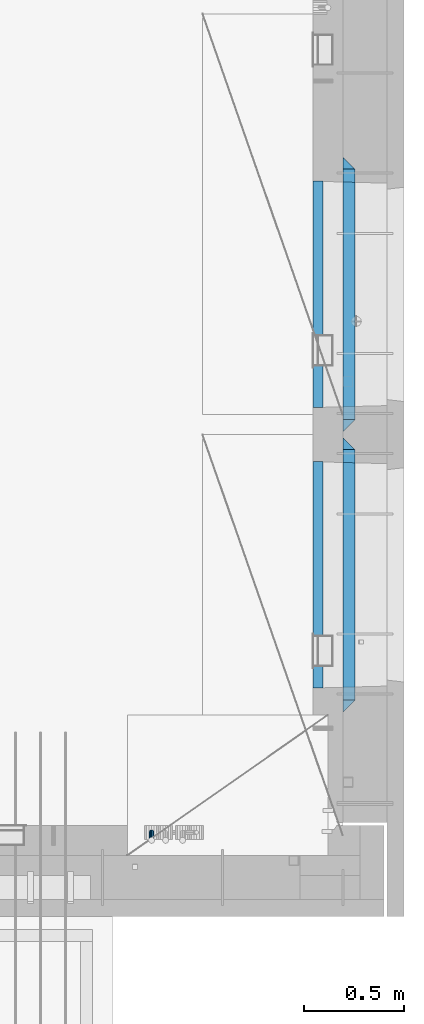
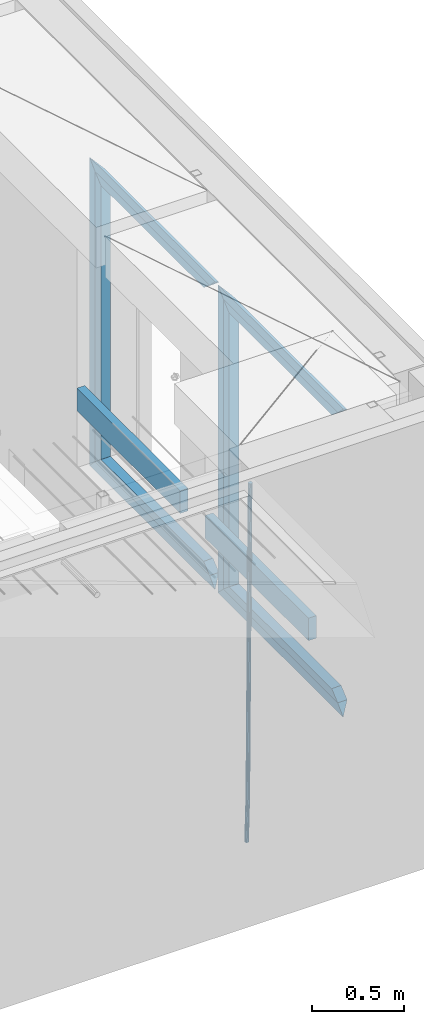
# One storey, part 131 of 349: 15 beams, 2 elements without a shape of their own.
"""IFC2X3 building model written with IfcOpenShell, lengths in millimetres."""

from ifc_helpers import new_model, si_unit, frame, origin_with_axes, place, context, subcontext, project, spatial, faceted_brep, material, type_object, element, aggregate, save


model = new_model("IFC2X3")

# Units and contexts
model_context = context("Model", 3, precision=1e-05, world=origin_with_axes())
body_context = subcontext(model_context, "Body", "Model", "MODEL_VIEW")
ifc_project = project(units=[si_unit("LENGTHUNIT", "METRE", prefix="MILLI"), si_unit("AREAUNIT", "SQUARE_METRE"), si_unit("VOLUMEUNIT", "CUBIC_METRE"), si_unit("MASSUNIT", "GRAM", prefix="KILO"), si_unit("TIMEUNIT", "SECOND"), si_unit("PLANEANGLEUNIT", "RADIAN"), si_unit("SOLIDANGLEUNIT", "STERADIAN"), si_unit("THERMODYNAMICTEMPERATUREUNIT", "DEGREE_CELSIUS"), si_unit("LUMINOUSINTENSITYUNIT", "LUMEN")], contexts=[model_context])

# Site, building, storey
site_placement = place(None, origin_with_axes())
site = spatial("IfcSite", under=ifc_project, at=site_placement, CompositionType="ELEMENT")
building_placement = place(site_placement, origin_with_axes())
building = spatial("IfcBuilding", under=site, at=building_placement, CompositionType="ELEMENT")
storey_placement = place(building_placement, origin_with_axes())
storey = spatial("IfcBuildingStorey", under=building, at=storey_placement, Name="4", CompositionType="ELEMENT", Elevation=0.0)

# Assembly, beam
assembly_1_placement = place(storey_placement, origin_with_axes())
assembly_1 = element("IfcElementAssembly", 1, at=assembly_1_placement, inside=storey, AssemblyPlace="NOTDEFINED", PredefinedType="REINFORCEMENT_UNIT")
ifc_material_1 = material()
beam_type_1 = type_object("IfcBeamType", Name="D25", PredefinedType="NOTDEFINED")
beam_1_placement = place(assembly_1_placement, frame((34104.9999999961, 7965.00000227913, 90990.0), z_axis=(0.00020576299992186, -0.999642804629538, -0.0267249099901004), x_axis=(-4.30000201928125e-08, -0.0267249099948059, 0.999642825806181)))
beam_1 = element("IfcBeam", 2, at=beam_1_placement, type_object=beam_type_1, material=ifc_material_1, Name="JM25", ObjectType="D25", context=body_context, shape_type="Brep", body=[
    faceted_brep([(-7.41420080885291e-08, -12.5, -3.63797880709171e-12), (-6.42030499875546e-08, -10.8253175473074, -6.25000000000364), (60.4103898235917, -10.8253175318459, -6.2499999938409), (60.4103898269532, -12.4999999845422, 6.16273609921336e-09), (-3.70782800018787e-08, -6.25000000000364, -10.8253175473074), (60.4103898202884, -6.24999998454587, -10.8253175411446), (-1.45519152283669e-11, -3.63797880709171e-12, -12.5), (60.4103898179019, 1.54577719513327e-08, -12.4999999938373), (3.70637280866504e-08, 6.25, -10.8253175473074), (60.410389817087, 6.25000001545777, -10.825317541141), (6.42030499875546e-08, 10.8253175473001, -6.25000000000364), (60.410389818062, 10.8253175627578, -6.24999999383726), (7.41420080885291e-08, 12.4999999999927, 0.0), (60.4103898205503, 12.5000000154541, 6.16273609921336e-09), (6.42176019027829e-08, 10.8253175473001, 6.24999999999636), (60.4103898238973, 10.8253175627651, 6.2500000061591), (3.70928319171071e-08, 6.24999999999636, 10.8253175473037), (60.4103898272151, 6.25000001546141, 10.8253175534664), (1.45519152283669e-11, -3.63797880709171e-12, 12.4999999999964), (60.4103898296162, 1.54541339725256e-08, 12.5000000061591), (-3.7049176171422e-08, -6.25000000000364, 10.8253175473001), (60.4103898304165, -6.24999998454587, 10.8253175534701), (-6.41884980723262e-08, -10.8253175473074, 6.25), (60.4103898294561, -10.8253175318459, 6.25000000616637), (61.0324985728803, -10.8253175316895, -6.24999999377542), (60.991802792938, -12.4999999843931, 6.22458173893392e-09), (61.0622854283865, -6.24999998437852, -10.8253175410755), (61.0731819955545, 1.5628756955266e-08, -12.4999999937718), (61.0622685480339, 6.25000001562512, -10.8253175410791), (61.032469335245, 10.8253175629216, -6.24999999377178), (60.9917690322181, 12.5000000156033, 6.22458173893392e-09), (60.9510732522613, 10.8253175629034, 6.25000000621731), (60.9212863967696, 6.25000001558874, 10.8253175535247), (60.9103898296162, 1.55814632307738e-08, 12.5000000062137), (60.9213032771368, -6.24999998441126, 10.8253175535174), (60.9511024898966, -10.8253175317113, 6.25000000621731), (61.6545545670233, -10.8253158516927, -6.24189838219536), (61.573166454793, -12.499998414296, 0.00757164385504439), (61.7141257553885, -6.24999822394238, -10.8168280205282), (61.7359179680789, 1.80548886419274e-06, -12.491368569139), (61.7140919992817, 6.25000177601396, -10.8168282403167), (61.6544960997562, 10.8253192428383, -6.2418987628771), (61.5730989426083, 12.5000015856094, 0.0075712042817031), (61.4917108303925, 10.8253190230062, 6.25704123032847), (61.4321396420273, 6.25000139525582, 10.8319708686649), (61.4103474293224, 1.36582457344048e-06, 12.5065114172721), (61.4321733981196, -6.24999860470052, 10.8319710884571), (61.4917692976451, -10.8253160715249, 6.25704161101385), (176.524302641745, -10.8250056210964, -4.74584321979273), (176.442914529529, -12.4996881836996, 1.50362680625403), (176.583873830095, -6.24968799334965, -9.3207728581292), (176.605666042786, 0.000312036081595579, -10.9953134067364), (176.583840074018, 6.25031200660669, -9.32077307791769), (176.524244174492, 10.8256294734347, -4.74584360047811), (176.44284701733, 12.5003118162058, 1.50362636668069), (176.361458905099, 10.8256292535989, 7.75309639272746), (176.301887716749, 6.25031162585219, 12.3280260310676), (176.280095504058, 0.000311596420942806, 14.0025665796711), (176.301921472827, -6.24968837410415, 12.3280262508561), (176.361517372367, -10.8250058409321, 7.75309677341284), (177.085397012124, -10.8250041057399, -4.73853556792164), (176.983633547483, -12.4996867233749, 1.51066909103247), (177.159881729676, -6.24968643771717, -9.31327097355097), (177.187129580227, 0.000313606451527448, -10.987740468332), (177.159839524218, 6.25031356221734, -9.31327130338468), (177.085323910098, 10.8256309887511, -4.73853613920801), (176.983549136537, 12.5003132764905, 1.51066843136869), (176.881785671867, 10.8256306588555, 7.7598730903228), (176.80730095433, 6.25031299082912, 12.3346084959521), (176.780053103794, 0.000312946667690994, 14.0090779907332), (176.807343159802, -6.2496870091054, 12.3346088257895), (176.881858773908, -10.8250044356355, 7.7598736616128), (177.646431799818, -10.8250018318176, -4.72756919822132), (177.524295146417, -12.4996845320202, 1.52123723245313), (177.735828462886, -6.24968410334986, -9.30201312475765), (177.768531371941, 0.00031596292683389, -10.9763759912421), (177.735777808921, 6.25031589654827, -9.30201361973741), (177.646344064575, 10.8256332626152, -4.72757005553649), (177.524193838486, 12.5003154677688, 1.52123624250817), (177.402057185071, 10.8256327675663, 7.77004267317898), (177.312660521988, 6.2503150390985, 12.3444865997226), (177.279957612933, 0.00031497282179771, 14.0188494661961), (177.312711175953, -6.24968496079964, 12.3444870946951), (177.402144920314, -10.8250023268702, 7.77004353049415), (299.377443161706, -10.8245084454466, -2.34813158632096), (299.255306508276, -12.4991911456491, 3.90067484435349), (299.466839824803, -6.24919071697514, -6.92257551286093), (299.499542733873, 0.0008093492979242, -8.59693837933446), (299.466789170867, 6.250809282923, -6.92257600783341), (299.377355426492, 10.8261266489935, -2.34813244364341), (299.255205200388, 12.5008088541435, 3.90067385440125), (299.133068546944, 10.826126153941, 10.1494802850757), (299.043671883861, 6.25080842546959, 14.7239242116229), (299.010968974762, 0.000808359200163977, 16.3982870780892), (299.043722537797, -6.24919157442127, 14.7239247065918), (299.133156282158, -10.8245089404954, 10.1494811423981), (299.98561436501, -10.8245059804758, -2.33624385599614), (299.97179243555, -12.4991882411778, 3.91467976726199), (299.995742293278, -6.24918857328521, -6.91223722345239), (299.999447243041, 0.000811375455668895, -8.58716690387519), (299.995736475976, 6.25081142679483, -6.91223684201032), (299.985604289133, 10.8261291142808, -2.33624319533556), (299.971750386685, 12.5008117588586, 3.91467993563856), (299.957928457196, 10.8261294971744, 10.1656035610831), (299.947800528913, 6.25081208998381, 14.7415969285394), (299.944095579151, 0.00081214124293183, 16.4165266089549), (299.947806346216, -6.24918791008895, 14.7415965471009), (299.957938533058, -10.8245055975785, 10.1656029004225), (300.593832239858, -10.8245078794353, -2.34543881707941), (300.688302931099, -12.4991904788549, 3.90384712594823), (300.524685350189, -6.24919022474205, -6.92023371784308), (300.499390115292, 0.000809814544481924, -8.59472497713432), (300.524724372954, 6.25080977519247, -6.92023401429469), (300.593899829313, 10.8261272150703, -2.34543933054374), (300.688380976673, 12.5008095210287, 3.90384653304136), (300.782851667915, 10.8261269216127, 10.1531324760799), (300.851998557599, 6.25080926691589, 14.7279273768363), (300.877293792495, 0.000809227632998955, 16.4024186361276), (300.851959534804, -6.24919073302226, 14.7279276732806), (300.782784078474, -10.8245081728965, 10.153132989537), (2293.32930409742, -10.8307295605009, -32.4713622331001), (2293.42377478865, -12.5054121599169, -26.2220762900724), (2293.26015720774, -6.2554119058077, -37.0461571338565), (2293.23486197284, -0.00541186651753378, -38.7206483931477), (2293.26019623051, 6.24458809413409, -37.0461574303008), (2293.32937168686, 10.8199055340046, -32.4713627465644), (2293.42385283421, 12.4945878399631, -26.2220768829684), (2293.51832352545, 10.8199052405434, -19.972790939948), (2293.58747041514, 6.24458758585388, -15.3979960391844), (2293.61276565003, -0.00541245343265473, -13.7235047798931), (2293.58743139236, -6.25541241408428, -15.3979957427327), (2293.51825593603, -10.8307298539585, -19.9727904264691), (2294.0420846676, -10.8307317859326, -32.4821379598216), (2294.03681932652, -12.5054140739521, -26.2313442200393), (2294.06778164886, -6.2554144273563, -37.0583666982457), (2294.10702478497, -0.00541458957013674, -38.7338336404937), (2294.14929890928, 6.24458531819619, -37.0595987724118), (2294.18327670435, 10.8199028679592, -32.4842719748667), (2294.1998538474, 12.4945854171456, -26.2338083683717), (2294.19458850632, 10.819903129126, -19.9830146285858), (2294.16889152506, 6.24458577054975, -15.4067858901581), (2294.12964838895, -0.0054140672327776, -13.7313189479173), (2294.08737426462, -6.2554139749991, -15.4055538159919), (2294.05339646956, -10.8307315247621, -19.9808806135297), (2294.75482297382, -10.84002603931, -32.4726521173216), (2294.64982751427, -12.513407826169, -26.2231856868602), (2294.87535820232, -6.26594539088183, -37.0476186524102), (2294.97913588268, -0.0167870967634371, -38.7222267036377), (2295.0383488692, 6.23299192477134, -37.0477663960555), (2295.03713108998, 10.8087684320271, -32.4729080168181), (2294.97580884799, 12.4844668051373, -26.2234811741473), (2294.87081338844, 10.8110850182784, -19.9740147436787), (2294.7502781599, 6.23700436985018, -15.3990482086047), (2294.64650047956, -0.0121539242718427, -13.7244401573698), (2294.58728749304, -6.26193294580662, -15.3989004649666), (2294.58850527227, -10.8377094530588, -19.9737588441894), (2316.44667268227, -11.1228921988077, -32.1839550346631), (2316.34167722271, -12.7962739856739, -25.9344886042054), (2316.56720791078, -6.54881155039038, -36.7589215697517), (2316.67098559113, -0.299653256264719, -38.4335296209792), (2316.73019857766, 5.95012576527006, -36.759069313397), (2316.72898079845, 10.5259022725259, -32.1842109341669), (2316.66765855643, 12.2016006456361, -25.9347840914961), (2316.56266309689, 10.5282188587698, -19.6853176610275), (2316.44212786836, 5.95413821035254, -15.1103511259389), (2316.33835018802, -0.295020083769487, -13.4357430747186), (2316.27913720149, -6.54479910530426, -15.1102033823008), (2316.28035498071, -11.1205756125637, -19.685061761531), (2317.13234804722, -11.1318335458927, -32.1748293731798), (2317.04181141085, -12.8054038787741, -25.9251705100723), (2317.2154741603, -6.5572650749491, -36.7502937866229), (2317.26891617525, -0.307450393454928, -38.4255717558117), (2317.27835434731, 5.94297770185585, -36.7517739018112), (2317.24125972588, 10.5192220504723, -32.1773930078925), (2317.16757178486, 12.1950816748285, -25.9281307404563), (2317.0770351485, 10.5215113419545, -19.6784718773561), (2316.99390903539, 5.94694287101083, -15.1030074639057), (2316.94046702047, -0.302871810494253, -13.4277294947169), (2316.9310288484, -6.55329990579412, -15.1015273487101), (2316.96812346982, -11.1295442544142, -19.6759082426288), (2317.81808136747, -11.1298054502913, -32.1659056455355), (2317.74200467508, -12.803315894289, -25.9160547315114), (2317.86379538118, -6.55536082026447, -36.7418676070083), (2317.8668976831, -0.305700748642266, -38.417815303761), (2317.82655701396, 5.94458339541234, -36.7446799039099), (2317.75358262347, 10.5207330230332, -32.1707766866384), (2317.66752794063, 12.1965725370646, -25.9216793252963), (2317.59145124823, 10.5230620930706, -19.6718284112721), (2317.54573723453, 5.94861746304377, -15.0958664497994), (2317.54263493262, -0.301042608574789, -13.4199187530394), (2317.58297560175, -6.55132675263303, -15.0930541529051), (2317.65594999224, -11.1274763802539, -19.6669573701693), (2417.81884292323, -10.831603083323, -30.8687911350135), (2417.74276623082, -12.505113527317, -24.618940220982), (2417.86455693691, -6.25715845329614, -35.4447530964935), (2417.86765923884, -0.00749838167394046, -37.1207007932499), (2417.82731856969, 6.24278576237703, -35.4475653933878), (2417.75434417921, 10.8189353900088, -30.8736621761236), (2417.66828949639, 12.494774904033, -24.6245648147851), (2417.59221280397, 10.8212644600353, -18.3747139007501), (2417.54649879028, 6.2468198300121, -13.79875193927), (2417.54339648837, -0.00284024161010166, -12.1228042425173), (2417.5837371575, -6.25312438566107, -13.795939642383), (2417.65671154798, -10.8292740132893, -18.3698428596399)], [[[0, 1, 2, 3]], [[1, 4, 5, 2]], [[4, 6, 7, 5]], [[6, 8, 9, 7]], [[8, 10, 11, 9]], [[10, 12, 13, 11]], [[12, 14, 15, 13]], [[14, 16, 17, 15]], [[16, 18, 19, 17]], [[18, 20, 21, 19]], [[20, 22, 23, 21]], [[22, 0, 3, 23]], [[22, 20, 18, 16, 14, 12, 10, 8, 6, 4, 1, 0]], [[3, 2, 24, 25]], [[2, 5, 26, 24]], [[5, 7, 27, 26]], [[7, 9, 28, 27]], [[9, 11, 29, 28]], [[11, 13, 30, 29]], [[13, 15, 31, 30]], [[15, 17, 32, 31]], [[17, 19, 33, 32]], [[19, 21, 34, 33]], [[21, 23, 35, 34]], [[23, 3, 25, 35]], [[25, 24, 36, 37]], [[24, 26, 38, 36]], [[26, 27, 39, 38]], [[27, 28, 40, 39]], [[28, 29, 41, 40]], [[29, 30, 42, 41]], [[30, 31, 43, 42]], [[31, 32, 44, 43]], [[32, 33, 45, 44]], [[33, 34, 46, 45]], [[34, 35, 47, 46]], [[35, 25, 37, 47]], [[37, 36, 48, 49]], [[36, 38, 50, 48]], [[38, 39, 51, 50]], [[39, 40, 52, 51]], [[40, 41, 53, 52]], [[41, 42, 54, 53]], [[42, 43, 55, 54]], [[43, 44, 56, 55]], [[44, 45, 57, 56]], [[45, 46, 58, 57]], [[46, 47, 59, 58]], [[47, 37, 49, 59]], [[49, 48, 60, 61]], [[48, 50, 62, 60]], [[50, 51, 63, 62]], [[51, 52, 64, 63]], [[52, 53, 65, 64]], [[53, 54, 66, 65]], [[54, 55, 67, 66]], [[55, 56, 68, 67]], [[56, 57, 69, 68]], [[57, 58, 70, 69]], [[58, 59, 71, 70]], [[59, 49, 61, 71]], [[61, 60, 72, 73]], [[60, 62, 74, 72]], [[62, 63, 75, 74]], [[63, 64, 76, 75]], [[64, 65, 77, 76]], [[65, 66, 78, 77]], [[66, 67, 79, 78]], [[67, 68, 80, 79]], [[68, 69, 81, 80]], [[69, 70, 82, 81]], [[70, 71, 83, 82]], [[71, 61, 73, 83]], [[73, 72, 84, 85]], [[72, 74, 86, 84]], [[74, 75, 87, 86]], [[75, 76, 88, 87]], [[76, 77, 89, 88]], [[77, 78, 90, 89]], [[78, 79, 91, 90]], [[79, 80, 92, 91]], [[80, 81, 93, 92]], [[81, 82, 94, 93]], [[82, 83, 95, 94]], [[83, 73, 85, 95]], [[85, 84, 96, 97]], [[84, 86, 98, 96]], [[86, 87, 99, 98]], [[87, 88, 100, 99]], [[88, 89, 101, 100]], [[89, 90, 102, 101]], [[90, 91, 103, 102]], [[91, 92, 104, 103]], [[92, 93, 105, 104]], [[93, 94, 106, 105]], [[94, 95, 107, 106]], [[95, 85, 97, 107]], [[97, 96, 108, 109]], [[96, 98, 110, 108]], [[98, 99, 111, 110]], [[99, 100, 112, 111]], [[100, 101, 113, 112]], [[101, 102, 114, 113]], [[102, 103, 115, 114]], [[103, 104, 116, 115]], [[104, 105, 117, 116]], [[105, 106, 118, 117]], [[106, 107, 119, 118]], [[107, 97, 109, 119]], [[109, 108, 120, 121]], [[108, 110, 122, 120]], [[110, 111, 123, 122]], [[111, 112, 124, 123]], [[112, 113, 125, 124]], [[113, 114, 126, 125]], [[114, 115, 127, 126]], [[115, 116, 128, 127]], [[116, 117, 129, 128]], [[117, 118, 130, 129]], [[118, 119, 131, 130]], [[119, 109, 121, 131]], [[121, 120, 132, 133]], [[120, 122, 134, 132]], [[122, 123, 135, 134]], [[123, 124, 136, 135]], [[124, 125, 137, 136]], [[125, 126, 138, 137]], [[126, 127, 139, 138]], [[127, 128, 140, 139]], [[128, 129, 141, 140]], [[129, 130, 142, 141]], [[130, 131, 143, 142]], [[131, 121, 133, 143]], [[133, 132, 144, 145]], [[132, 134, 146, 144]], [[134, 135, 147, 146]], [[135, 136, 148, 147]], [[136, 137, 149, 148]], [[137, 138, 150, 149]], [[138, 139, 151, 150]], [[139, 140, 152, 151]], [[140, 141, 153, 152]], [[141, 142, 154, 153]], [[142, 143, 155, 154]], [[143, 133, 145, 155]], [[145, 144, 156, 157]], [[144, 146, 158, 156]], [[146, 147, 159, 158]], [[147, 148, 160, 159]], [[148, 149, 161, 160]], [[149, 150, 162, 161]], [[150, 151, 163, 162]], [[151, 152, 164, 163]], [[152, 153, 165, 164]], [[153, 154, 166, 165]], [[154, 155, 167, 166]], [[155, 145, 157, 167]], [[157, 156, 168, 169]], [[156, 158, 170, 168]], [[158, 159, 171, 170]], [[159, 160, 172, 171]], [[160, 161, 173, 172]], [[161, 162, 174, 173]], [[162, 163, 175, 174]], [[163, 164, 176, 175]], [[164, 165, 177, 176]], [[165, 166, 178, 177]], [[166, 167, 179, 178]], [[167, 157, 169, 179]], [[169, 168, 180, 181]], [[168, 170, 182, 180]], [[170, 171, 183, 182]], [[171, 172, 184, 183]], [[172, 173, 185, 184]], [[173, 174, 186, 185]], [[174, 175, 187, 186]], [[175, 176, 188, 187]], [[176, 177, 189, 188]], [[177, 178, 190, 189]], [[178, 179, 191, 190]], [[179, 169, 181, 191]], [[181, 180, 192, 193]], [[180, 182, 194, 192]], [[182, 183, 195, 194]], [[183, 184, 196, 195]], [[184, 185, 197, 196]], [[185, 186, 198, 197]], [[186, 187, 199, 198]], [[187, 188, 200, 199]], [[188, 189, 201, 200]], [[189, 190, 202, 201]], [[190, 191, 203, 202]], [[191, 181, 193, 203]], [[194, 195, 196, 197, 198, 199, 200, 201, 202, 203, 193, 192]]]),
])
aggregate(assembly_1, [beam_1])

# Assembly, beams
assembly_2_placement = place(storey_placement, origin_with_axes())
assembly_2 = element("IfcElementAssembly", 3, at=assembly_2_placement, inside=storey, AssemblyPlace="NOTDEFINED", PredefinedType="REINFORCEMENT_UNIT")
ifc_material_2 = material(Name="TIMBER/T24")
beam_type_2 = type_object("IfcBeamType", PredefinedType="NOTDEFINED")
beam_2_placement = place(assembly_2_placement, frame((34935.0002758707, 8685.00118845241, 91685.0), z_axis=(0.0, 0.0, 1.0), x_axis=(0.0, 1.0, 0.0)))
beam_2 = element("IfcBeam", 4, at=beam_2_placement, type_object=beam_type_2, material=ifc_material_2, context=body_context, shape_type="Brep", body=[
    faceted_brep([(-3.63797880709171e-12, 24.9999999999964, -75.0), (-3.63797880709171e-12, 24.9999999999964, 75.0), (1130.0, 25.0, 75.0), (1130.0, 25.0, -75.0), (0.0, -25.0000000000073, 75.0), (1130.0, -25.0, 75.0), (0.0, -25.0000000000073, -75.0), (1130.0, -25.0, -75.0)], [[[0, 1, 2, 3]], [[1, 4, 5, 2]], [[4, 6, 7, 5]], [[6, 0, 3, 7]], [[5, 7, 3, 2]], [[6, 4, 1, 0]]]),
])
beam_3_placement = place(assembly_2_placement, frame((34935.0002758707, 10085.0011884524, 91685.0), z_axis=(0.0, 0.0, 1.0), x_axis=(0.0, 1.0, 0.0)))
beam_3 = element("IfcBeam", 5, at=beam_3_placement, type_object=beam_type_2, material=ifc_material_2, context=body_context, shape_type="Brep", body=[
    faceted_brep([(-3.63797880709171e-12, 24.9999999999964, -75.0), (-3.63797880709171e-12, 24.9999999999964, 75.0), (1130.0, 25.0, 75.0), (1130.0, 25.0, -75.0), (0.0, -25.0000000000073, 75.0), (1130.0, -25.0, 75.0), (0.0, -25.0000000000073, -75.0), (1130.0, -25.0, -75.0)], [[[0, 1, 2, 3]], [[1, 4, 5, 2]], [[4, 6, 7, 5]], [[6, 0, 3, 7]], [[5, 7, 3, 2]], [[6, 4, 1, 0]]]),
])
ifc_material_3 = material(Name="CONCRETE/C25/30")
beam_type_3 = type_object("IfcBeamType", PredefinedType="NOTDEFINED")
beam_4_placement = place(assembly_2_placement, frame((35090.0, 8565.0001381367, 93145.0), z_axis=(0.0, 0.0, -1.0), x_axis=(0.0, 1.0, 0.0)))
beam_4 = element("IfcBeam", 6, at=beam_4_placement, type_object=beam_type_3, material=ifc_material_3, Name="SK", context=body_context, shape_type="Brep", body=[
    faceted_brep([(60.0000000000073, 30.0, 30.0), (0.0, -30.0, -30.0), (60.0000000000073, -30.0, 30.0), (1309.99990463256, 30.0, 30.0), (1369.99990463257, -30.0, -30.0), (1309.99990463256, -30.0, 30.0)], [[[0, 1, 2]], [[1, 0, 3, 4]], [[2, 1, 4, 5]], [[0, 2, 5, 3]], [[4, 3, 5]]]),
])
beam_5_placement = place(assembly_2_placement, frame((35090.0, 8625.0001381367, 93085.0), z_axis=(0.0, 0.0, -1.0), x_axis=(0.0, 1.0, 0.0)))
beam_5 = element("IfcBeam", 7, at=beam_5_placement, type_object=beam_type_3, material=ifc_material_3, Name="SK", context=body_context, shape_type="Brep", body=[
    faceted_brep([(65.6755803082433, 30.0, 25.6756756756804), (64.0539586866216, -30.0, 24.0540540540533), (1185.94585057852, -30.0, 24.0540540540533), (1184.32422895689, 30.0, 25.6756756756804), (65.6755803082433, 30.0, 26.2933545375708), (64.0539586866216, -30.0, 24.9033931479062), (0.0, -30.0, -30.0), (0.0, 30.0, -30.0), (1249.99990463257, 30.0, -30.0), (1249.99990463257, -30.0, -30.0), (1185.94585057852, -30.0, 24.9034748914273), (1184.32422895689, 30.0, 26.293436281092)], [[[0, 1, 2, 3]], [[1, 0, 4, 5]], [[6, 5, 4, 7]], [[6, 7, 8, 9]], [[2, 1, 5, 6, 9, 10]], [[3, 2, 10, 11]], [[7, 4, 0, 3, 11, 8]], [[10, 9, 8, 11]]]),
])
beam_6_placement = place(assembly_2_placement, frame((35090.0, 9905.00004276927, 93175.0), z_axis=(0.0, -1.0, 0.0), x_axis=(0.0, 0.0, -1.0)))
beam_6 = element("IfcBeam", 8, at=beam_6_placement, type_object=beam_type_3, material=ifc_material_3, Name="SK", context=body_context, shape_type="Brep", body=[
    faceted_brep([(60.0000000000073, 30.0, 30.0), (0.0, -30.0, -30.0), (60.0000000000073, -30.0, 30.0), (1995.0, 30.0, 30.0), (2055.0, -30.0, -30.0), (1995.0, -30.0, 30.0)], [[[0, 1, 2]], [[3, 4, 1, 0]], [[4, 5, 2, 1]], [[5, 3, 0, 2]], [[5, 4, 3]]]),
])
beam_7_placement = place(assembly_2_placement, frame((35090.0, 9875.00004276927, 91210.0), z_axis=(0.0, 0.0, 1.0), x_axis=(0.0, -1.0, 0.0)))
beam_7 = element("IfcBeam", 9, at=beam_7_placement, type_object=beam_type_3, material=ifc_material_3, Name="SK", context=body_context, shape_type="Brep", body=[
    faceted_brep([(1185.94594588314, -29.9999988381387, 24.0540541168593), (1184.32432432432, 29.9999988381387, 25.6756756756804), (65.6756756756768, 30.0, 25.6756756756804), (64.0540540540533, -30.0, 24.0540540540533), (1185.94594594595, -30.0, 24.9033931479207), (1184.32432432433, 30.0, 26.2933545375854), (1249.99990463257, -30.0, -30.0), (1249.99990463257, 30.0, -30.0), (0.0, 30.0, -30.0), (65.6756756756768, 30.0, 26.293436281092), (64.0540540540533, -30.0, 24.9034748914419), (0.0, -30.0, -30.0)], [[[0, 1, 2, 3]], [[1, 0, 4, 5]], [[6, 7, 5, 4]], [[2, 1, 5, 7, 8, 9]], [[3, 2, 9, 10]], [[6, 4, 0, 3, 10, 11]], [[11, 8, 7, 6]], [[11, 10, 9, 8]]]),
])
beam_8_placement = place(assembly_2_placement, frame((35090.0, 9935.00004276927, 91150.0), z_axis=(0.0, 0.0, 1.0), x_axis=(0.0, -1.0, 0.0)))
beam_8 = element("IfcBeam", 10, at=beam_8_placement, type_object=beam_type_3, material=ifc_material_3, Name="SK", context=body_context, shape_type="Brep", body=[
    faceted_brep([(1369.99990463257, -30.0, -30.0), (1309.99990463256, 30.0, 30.0), (1309.99990463256, -30.0, 30.0), (60.0000000000073, 30.0, 30.0), (60.0000000000073, -30.0, 30.0), (0.0, -30.0, -30.0)], [[[0, 1, 2]], [[3, 4, 2, 1]], [[4, 5, 0, 2]], [[5, 3, 1, 0]], [[3, 5, 4]]]),
])
beam_9_placement = place(assembly_2_placement, frame((35090.0, 9965.00023350414, 93145.0), z_axis=(0.0, 0.0, -1.0), x_axis=(0.0, 1.0, 0.0)))
beam_9 = element("IfcBeam", 11, at=beam_9_placement, type_object=beam_type_3, material=ifc_material_3, Name="SK", context=body_context, shape_type="Brep", body=[
    faceted_brep([(60.0000000000073, 30.0, 30.0), (0.0, -30.0, -30.0), (60.0000000000073, -30.0, 30.0), (1309.99942779541, 30.0, 30.0), (1369.99942779541, -30.0, -30.0), (1309.99942779541, -30.0, 30.0)], [[[0, 1, 2]], [[1, 0, 3, 4]], [[2, 1, 4, 5]], [[0, 2, 5, 3]], [[4, 3, 5]]]),
])
beam_10_placement = place(assembly_2_placement, frame((35090.0, 10025.0002335041, 93085.0), z_axis=(0.0, 0.0, -1.0), x_axis=(0.0, 1.0, 0.0)))
beam_10 = element("IfcBeam", 12, at=beam_10_placement, type_object=beam_type_3, material=ifc_material_3, Name="SK", context=body_context, shape_type="Brep", body=[
    faceted_brep([(65.6751034710851, 30.0, 25.6756756756804), (64.0534818494634, -30.0, 24.0540540540533), (1185.94537374136, -30.0, 24.0540540540533), (1184.32375211974, 30.0, 25.6756756756804), (65.6751034710851, 30.0, 26.2929458199942), (64.0534818494634, -30.0, 24.9029844303586), (0.0, -30.0, -30.0), (0.0, 30.0, -30.0), (1249.99942779541, 30.0, -30.0), (1249.99942779541, -30.0, -30.0), (1185.94537374136, -30.0, 24.9034748914273), (1184.32375211974, 30.0, 26.293436281092)], [[[0, 1, 2, 3]], [[1, 0, 4, 5]], [[6, 5, 4, 7]], [[6, 7, 8, 9]], [[2, 1, 5, 6, 9, 10]], [[3, 2, 10, 11]], [[7, 4, 0, 3, 11, 8]], [[10, 9, 8, 11]]]),
])
beam_11_placement = place(assembly_2_placement, frame((35090.0, 11304.9996612995, 93175.0), z_axis=(0.0, -1.0, 0.0), x_axis=(0.0, 0.0, -1.0)))
beam_11 = element("IfcBeam", 13, at=beam_11_placement, type_object=beam_type_3, material=ifc_material_3, Name="SK", context=body_context, shape_type="Brep", body=[
    faceted_brep([(60.0000000000073, 30.0, 30.0), (0.0, -30.0, -30.0), (60.0000000000073, -30.0, 30.0), (1995.0, 30.0, 30.0), (2055.0, -30.0, -30.0), (1995.0, -30.0, 30.0)], [[[0, 1, 2]], [[3, 4, 1, 0]], [[4, 5, 2, 1]], [[5, 3, 0, 2]], [[5, 4, 3]]]),
])
beam_12_placement = place(assembly_2_placement, frame((35090.0, 11274.9996612995, 91210.0), z_axis=(0.0, 0.0, 1.0), x_axis=(0.0, -1.0, 0.0)))
beam_12 = element("IfcBeam", 14, at=beam_12_placement, type_object=beam_type_3, material=ifc_material_3, Name="SK", context=body_context, shape_type="Brep", body=[
    faceted_brep([(1185.94594588314, -29.9999988381387, 24.0540541168593), (1184.32432432432, 29.9999988381387, 25.6756756756804), (65.6756756756768, 30.0, 25.6756756756804), (64.0540540540533, -30.0, 24.0540540540533), (1185.94594594595, -30.0, 24.9029844303586), (1184.32432432433, 30.0, 26.2929458200088), (1249.99942779541, -30.0, -30.0), (1249.99942779541, 30.0, -30.0), (0.0, 30.0, -30.0), (65.6756756756768, 30.0, 26.293436281092), (64.0540540540533, -30.0, 24.9034748914419), (0.0, -30.0, -30.0)], [[[0, 1, 2, 3]], [[1, 0, 4, 5]], [[6, 7, 5, 4]], [[2, 1, 5, 7, 8, 9]], [[3, 2, 9, 10]], [[6, 4, 0, 3, 10, 11]], [[11, 8, 7, 6]], [[11, 10, 9, 8]]]),
])
beam_13_placement = place(assembly_2_placement, frame((35090.0, 11334.9996612995, 91150.0), z_axis=(0.0, 0.0, 1.0), x_axis=(0.0, -1.0, 0.0)))
beam_13 = element("IfcBeam", 15, at=beam_13_placement, type_object=beam_type_3, material=ifc_material_3, Name="SK", context=body_context, shape_type="Brep", body=[
    faceted_brep([(1369.99942779541, -30.0, -30.0), (1309.99942779541, 30.0, 30.0), (1309.99942779541, -30.0, 30.0), (60.0000000000073, 30.0, 30.0), (60.0000000000073, -30.0, 30.0), (0.0, -30.0, -30.0)], [[[0, 1, 2]], [[3, 4, 2, 1]], [[4, 5, 0, 2]], [[5, 3, 1, 0]], [[3, 5, 4]]]),
])
beam_type_4 = type_object("IfcBeamType", PredefinedType="NOTDEFINED")
beam_14_placement = place(assembly_2_placement, frame((35090.0, 9840.00004276927, 93115.0), z_axis=(0.0, -1.0, 0.0), x_axis=(0.0, 0.0, -1.0)))
beam_14 = element("IfcBeam", 16, at=beam_14_placement, type_object=beam_type_4, material=ifc_material_3, Name="SK", context=body_context, shape_type="Brep", body=[
    faceted_brep([(0.0, -30.0, -35.0), (54.9034748914273, -30.0, 29.0540540540533), (56.2934362811066, 30.0, 30.6756756756768), (0.0, 30.0, -35.0), (1935.0, 30.0, -35.0), (1935.0, -30.0, -35.0), (1880.09652510857, -30.0, 29.0540540540533), (1878.70656371891, 30.0, 30.6756756756749)], [[[0, 1, 2, 3]], [[4, 5, 0, 3]], [[1, 0, 5, 6]], [[2, 1, 6, 7]], [[3, 2, 7, 4]], [[6, 5, 4, 7]]]),
])
beam_15_placement = place(assembly_2_placement, frame((35090.0, 11239.9996612995, 93115.0), z_axis=(0.0, -1.0, 0.0), x_axis=(0.0, 0.0, -1.0)))
beam_15 = element("IfcBeam", 17, at=beam_15_placement, type_object=beam_type_4, material=ifc_material_3, Name="SK", context=body_context, shape_type="Brep", body=[
    faceted_brep([(0.0, -30.0, -35.0), (54.9034748914273, -30.0, 29.0540540540533), (56.2934362811066, 30.0, 30.6756756756768), (0.0, 30.0, -35.0), (1935.0, 30.0, -35.0), (1935.0, -30.0, -35.0), (1880.09652510857, -30.0, 29.0540540540533), (1878.70656371891, 30.0, 30.6756756756749)], [[[0, 1, 2, 3]], [[4, 5, 0, 3]], [[1, 0, 5, 6]], [[2, 1, 6, 7]], [[3, 2, 7, 4]], [[6, 5, 4, 7]]]),
])
aggregate(assembly_2, [beam_2, beam_3, beam_4, beam_5, beam_6, beam_14, beam_7, beam_8, beam_9, beam_10, beam_11, beam_15, beam_12, beam_13])

save(model, "model.ifc")
